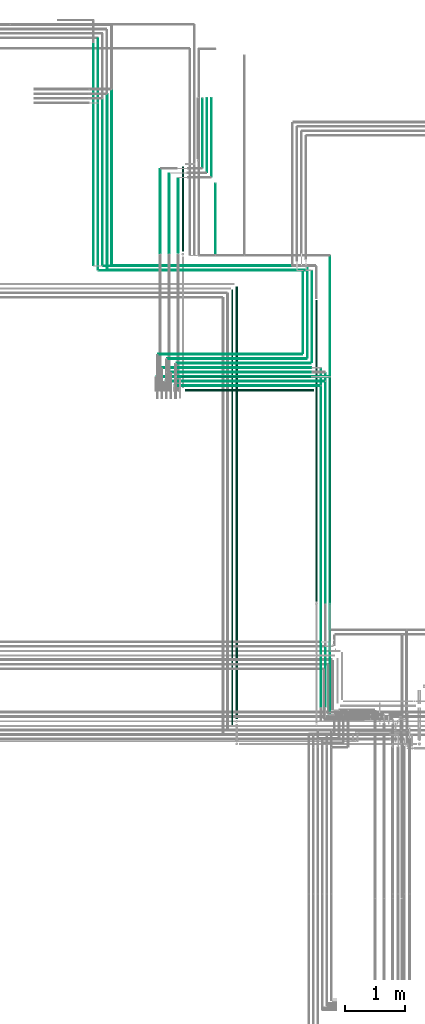
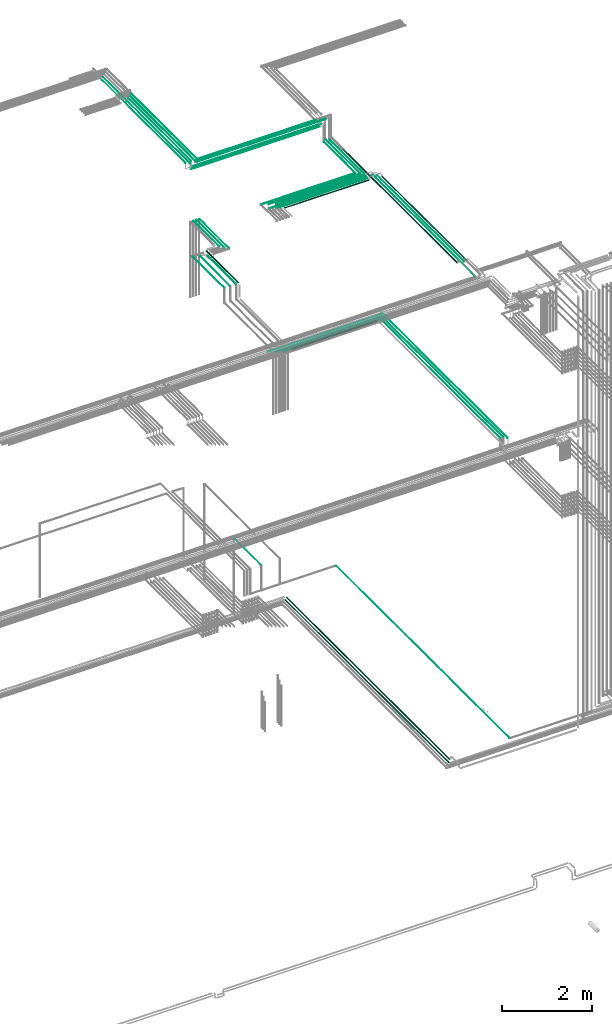
# One storey, part 110 of 331: 41 flow segments.
"""IFC2X3 building model written with IfcOpenShell, lengths in millimetres."""

from ifc_helpers import new_model, entity, si_unit, converted_unit, derived_unit, direction, frame, frame_2d, origin, origin_2d_with_axis, place, context, subcontext, project, spatial, circle, extrude, type_object, element, save


model = new_model("IFC2X3")

# Units and contexts
model_context = context("Model", 3, precision=0.01, world=origin(), true_north=direction((6.12303176911189e-17, 1.0)))
body_context = subcontext(model_context, "Body", "Model", "MODEL_VIEW")
ifc_project = project(units=[si_unit("LENGTHUNIT", "METRE", prefix="MILLI"), si_unit("AREAUNIT", "SQUARE_METRE"), si_unit("VOLUMEUNIT", "CUBIC_METRE"), converted_unit("PLANEANGLEUNIT", "DEGREE", entity("IfcRatioMeasure", 0.0174532925199433), si_unit("PLANEANGLEUNIT", "RADIAN"), dimensions=[0, 0, 0, 0, 0, 0, 0]), si_unit("MASSUNIT", "GRAM", prefix="KILO"), derived_unit("MASSDENSITYUNIT", [(si_unit("MASSUNIT", "GRAM", prefix="KILO"), 1), (si_unit("LENGTHUNIT", "METRE"), -3)]), derived_unit("MOMENTOFINERTIAUNIT", [(si_unit("LENGTHUNIT", "METRE"), 4)]), si_unit("TIMEUNIT", "SECOND"), si_unit("FREQUENCYUNIT", "HERTZ"), si_unit("THERMODYNAMICTEMPERATUREUNIT", "DEGREE_CELSIUS"), derived_unit("THERMALTRANSMITTANCEUNIT", [(si_unit("MASSUNIT", "GRAM", prefix="KILO"), 1), (si_unit("THERMODYNAMICTEMPERATUREUNIT", "KELVIN"), -1), (si_unit("TIMEUNIT", "SECOND"), -3)]), derived_unit("VOLUMETRICFLOWRATEUNIT", [(si_unit("LENGTHUNIT", "METRE"), 3), (si_unit("TIMEUNIT", "SECOND"), -1)]), derived_unit("MASSFLOWRATEUNIT", [(si_unit("MASSUNIT", "GRAM", prefix="KILO"), 1), (si_unit("TIMEUNIT", "SECOND"), -1)]), derived_unit("ROTATIONALFREQUENCYUNIT", [(si_unit("TIMEUNIT", "SECOND"), -1)]), si_unit("ELECTRICCURRENTUNIT", "AMPERE"), si_unit("ELECTRICVOLTAGEUNIT", "VOLT"), si_unit("POWERUNIT", "WATT"), si_unit("FORCEUNIT", "NEWTON", prefix="KILO"), si_unit("ILLUMINANCEUNIT", "LUX"), si_unit("LUMINOUSFLUXUNIT", "LUMEN"), si_unit("LUMINOUSINTENSITYUNIT", "CANDELA"), derived_unit("USERDEFINED", [(si_unit("MASSUNIT", "GRAM", prefix="KILO"), -1), (si_unit("LENGTHUNIT", "METRE"), -2), (si_unit("TIMEUNIT", "SECOND"), 3), (si_unit("LUMINOUSFLUXUNIT", "LUMEN"), 1)]), derived_unit("LINEARVELOCITYUNIT", [(si_unit("LENGTHUNIT", "METRE"), 1), (si_unit("TIMEUNIT", "SECOND"), -1)]), si_unit("PRESSUREUNIT", "PASCAL"), derived_unit("USERDEFINED", [(si_unit("LENGTHUNIT", "METRE"), -2), (si_unit("MASSUNIT", "GRAM", prefix="KILO"), 1), (si_unit("TIMEUNIT", "SECOND"), -2)]), derived_unit("LINEARFORCEUNIT", [(si_unit("MASSUNIT", "GRAM", prefix="KILO"), 1), (si_unit("LENGTHUNIT", "METRE"), 1), (si_unit("TIMEUNIT", "SECOND"), -2), (si_unit("LENGTHUNIT", "METRE"), -1)]), derived_unit("PLANARFORCEUNIT", [(si_unit("MASSUNIT", "GRAM", prefix="KILO"), 1), (si_unit("LENGTHUNIT", "METRE"), 1), (si_unit("TIMEUNIT", "SECOND"), -2), (si_unit("LENGTHUNIT", "METRE"), -2)])], contexts=[model_context])

# Site, building, storey
site_placement = place(None, frame((0.0, -0.00077364408347762, 0.0)))
site = spatial("IfcSite", under=ifc_project, at=site_placement, CompositionType="ELEMENT")
building_placement = place(site_placement, origin())
building = spatial("IfcBuilding", under=site, at=building_placement, CompositionType="ELEMENT")
storey_placement = place(building_placement, origin())
storey = spatial("IfcBuildingStorey", under=building, at=storey_placement, CompositionType="ELEMENT", Elevation=0.0)

# Flow segments
pipe_segment_type = type_object("IfcPipeSegmentType", PredefinedType="NOTDEFINED")
flow_segment_1_placement = place(storey_placement, frame((62212.5132590569, 8689.62056382736, 14742.4047277641)))
element("IfcFlowSegment", 1, at=flow_segment_1_placement, inside=storey, type_object=pipe_segment_type, context=body_context, shape_type="SweptSolid", body=[
    extrude(circle(Radius=6.0, at=origin_2d_with_axis()), frame((7.59527223591454, 0.0, 7.5952722359167), z_axis=(0.0, 1.0, 0.0), x_axis=(1.0, 0.0, 0.0)), (0.0, 0.0, 1.0), 5571.37943617266),
])
flow_segment_2_placement = place(storey_placement, frame((59329.8482219476, 14267.4047277641, 14692.4047277641)))
element("IfcFlowSegment", 2, at=flow_segment_2_placement, inside=storey, type_object=pipe_segment_type, context=body_context, shape_type="SweptSolid", body=[
    extrude(circle(Radius=6.0, at=origin_2d_with_axis()), frame((0.0, 7.5952722359297, 7.5952722359167), z_axis=(1.0, 0.0, 0.0), x_axis=(0.0, -1.0, 0.0)), (0.0, 0.0, 1.0), 2876.26030934531),
])
flow_segment_3_placement = place(storey_placement, frame((60239.5132627125, 17610.0, 15144.4047277641)))
element("IfcFlowSegment", 3, at=flow_segment_3_placement, inside=storey, type_object=pipe_segment_type, context=body_context, shape_type="SweptSolid", body=[
    extrude(circle(Radius=4.0, at=origin_2d_with_axis()), frame((5.59527223591499, 0.0, 5.59527223591499), z_axis=(0.0, 1.0, 0.0), x_axis=(1.0, 0.0, 0.0)), (0.0, 0.0, 1.0), 1311.62054191252),
])
flow_segment_4_placement = place(storey_placement, frame((62137.5132590569, 8764.62056382736, 14742.4047277641)))
element("IfcFlowSegment", 4, at=flow_segment_4_placement, inside=storey, type_object=pipe_segment_type, context=body_context, shape_type="SweptSolid", body=[
    extrude(circle(Radius=6.0, at=origin_2d_with_axis()), frame((7.59527223591454, 0.0, 7.5952722359167), z_axis=(0.0, 1.0, 0.0), x_axis=(1.0, 0.0, 0.0)), (0.0, 0.0, 1.0), 5421.37943617267),
])
flow_segment_5_placement = place(storey_placement, frame((62062.5132590569, 8764.62056382736, 14742.4047277641)))
element("IfcFlowSegment", 5, at=flow_segment_5_placement, inside=storey, type_object=pipe_segment_type, context=body_context, shape_type="SweptSolid", body=[
    extrude(circle(Radius=6.0, at=frame_2d((0.0, 2.16573425859679e-12), x_axis=(1.0, 0.0))), frame((7.59527223591454, 0.0, 7.59527223591887), z_axis=(0.0, 1.0, 0.0), x_axis=(1.0, 0.0, 0.0)), (0.0, 0.0, 1.0), 5346.37943617266),
])
flow_segment_6_placement = place(storey_placement, frame((59805.8482219476, 14030.9047277641, 14730.9047277641)))
element("IfcFlowSegment", 6, at=flow_segment_6_placement, inside=storey, type_object=pipe_segment_type, context=body_context, shape_type="SweptSolid", body=[
    extrude(circle(Radius=17.5, at=origin_2d_with_axis()), frame((0.0, 19.0952722359163, 19.0952722359163), z_axis=(1.0, 0.0, 0.0), x_axis=(0.0, -1.0, 0.0)), (0.0, 0.0, 1.0), 2149.26030934528),
])
flow_segment_7_placement = place(storey_placement, frame((59629.8482219476, 14117.4047277641, 14692.4047277641)))
element("IfcFlowSegment", 7, at=flow_segment_7_placement, inside=storey, type_object=pipe_segment_type, context=body_context, shape_type="SweptSolid", body=[
    extrude(circle(Radius=6.0, at=frame_2d((0.0, -2.16573425859679e-12), x_axis=(1.0, 0.0))), frame((0.0, 7.59527223592536, 7.59527223591454), z_axis=(1.0, 0.0, 0.0), x_axis=(0.0, -1.0, 0.0)), (0.0, 0.0, 1.0), 2426.26030934532),
])
flow_segment_8_placement = place(storey_placement, frame((59479.8482219475, 14192.4047277641, 14692.4047277641)))
element("IfcFlowSegment", 8, at=flow_segment_8_placement, inside=storey, type_object=pipe_segment_type, context=body_context, shape_type="SweptSolid", body=[
    extrude(circle(Radius=6.0, at=frame_2d((0.0, -2.16573425859679e-12), x_axis=(1.0, 0.0))), frame((0.0, 7.59527223592536, 7.59527223591454), z_axis=(1.0, 0.0, 0.0), x_axis=(0.0, -1.0, 0.0)), (0.0, 0.0, 1.0), 2651.26030934533),
])
flow_segment_9_placement = place(storey_placement, frame((60164.5132627125, 17685.0, 15144.4047277641)))
element("IfcFlowSegment", 9, at=flow_segment_9_placement, inside=storey, type_object=pipe_segment_type, context=body_context, shape_type="SweptSolid", body=[
    extrude(circle(Radius=4.0, at=origin_2d_with_axis()), frame((5.59527223591499, 0.0, 5.59527223591499), z_axis=(0.0, 1.0, 0.0), x_axis=(1.0, 0.0, 0.0)), (0.0, 0.0, 1.0), 1236.62054191252),
])
flow_segment_10_placement = place(storey_placement, frame((60087.5132627125, 17764.0, 15142.4047277641)))
element("IfcFlowSegment", 10, at=flow_segment_10_placement, inside=storey, type_object=pipe_segment_type, context=body_context, shape_type="SweptSolid", body=[
    extrude(circle(Radius=6.0, at=frame_2d((8.66293703438714e-12, 0.0), x_axis=(1.0, 0.0))), frame((7.59527223591454, 0.0, 7.5952722359167), z_axis=(0.0, 1.0, 0.0), x_axis=(-1.0, 0.0, 0.0)), (0.0, 0.0, 1.0), 1153.62054191252),
])
flow_segment_11_placement = place(storey_placement, frame((59383.2529497117, 16337.0683513783, 15142.4047277641)))
element("IfcFlowSegment", 11, at=flow_segment_11_placement, inside=storey, type_object=pipe_segment_type, context=body_context, shape_type="SweptSolid", body=[
    extrude(circle(Radius=6.0, at=origin_2d_with_axis()), frame((7.5952722359232, 0.0, 7.5952722359167), z_axis=(0.0, 1.0, 0.0), x_axis=(1.0, 0.0, 0.0)), (0.0, 0.0, 1.0), 1398.93167053658),
])
flow_segment_12_placement = place(storey_placement, frame((59533.2529497117, 16337.0683513783, 15142.4047277641)))
element("IfcFlowSegment", 12, at=flow_segment_12_placement, inside=storey, type_object=pipe_segment_type, context=body_context, shape_type="SweptSolid", body=[
    extrude(circle(Radius=6.0, at=origin_2d_with_axis()), frame((7.5952722359232, 0.0, 7.5952722359167), z_axis=(0.0, 1.0, 0.0), x_axis=(1.0, 0.0, 0.0)), (0.0, 0.0, 1.0), 1323.93167053657),
])
flow_segment_13_placement = place(storey_placement, frame((59681.7529497117, 16341.0683513783, 15140.9047277641)))
element("IfcFlowSegment", 13, at=flow_segment_13_placement, inside=storey, type_object=pipe_segment_type, context=body_context, shape_type="SweptSolid", body=[
    extrude(circle(Radius=7.5, at=frame_2d((0.0, -2.16573425859679e-12), x_axis=(1.0, 0.0))), frame((9.09527223591419, 0.0, 9.09527223591419), z_axis=(0.0, 1.0, 0.0), x_axis=(1.0, 0.0, 0.0)), (0.0, 0.0, 1.0), 1240.93167053658),
])
flow_segment_14_placement = place(storey_placement, frame((59746.7529497117, 16363.0683513783, 15130.9047277641)))
element("IfcFlowSegment", 14, at=flow_segment_14_placement, inside=storey, type_object=pipe_segment_type, context=body_context, shape_type="SweptSolid", body=[
    extrude(circle(Radius=17.5, at=frame_2d((-8.66293703438714e-12, 0.0), x_axis=(1.0, 0.0))), frame((19.0952722359379, 0.0, 19.0952722359163), z_axis=(0.0, 1.0, 0.0), x_axis=(1.0, 0.0, 0.0)), (0.0, 0.0, 1.0), 1421.93167053659),
])
flow_segment_15_placement = place(building_placement, frame((60309.3854351487, 16308.5068408728, 7344.40472776409)))
element("IfcFlowSegment", 15, at=flow_segment_15_placement, inside=storey, type_object=pipe_segment_type, context=body_context, shape_type="SweptSolid", body=[
    extrude(circle(Radius=4.0, at=origin_2d_with_axis()), frame((5.59527223591499, 0.0, 5.59527223591607), z_axis=(0.0, 1.0, 0.0), x_axis=(1.0, 0.0, 0.0)), (0.0, 0.0, 1.0), 1186.86112669117),
])
flow_segment_16_placement = place(storey_placement, frame((61977.0947663298, 10524.8107344822, 18430.9047277641)))
element("IfcFlowSegment", 16, at=flow_segment_16_placement, inside=storey, type_object=pipe_segment_type, context=body_context, shape_type="SweptSolid", body=[
    extrude(circle(Radius=17.5, at=origin_2d_with_axis()), frame((19.0952722359119, 0.0, 19.0952722359163), z_axis=(0.0, 1.0, 0.0), x_axis=(1.0, 0.0, 0.0)), (0.0, 0.0, 1.0), 5035.76431292158),
])
flow_segment_17_placement = place(storey_placement, frame((62063.5947663297, 9864.0, 18442.4047277641)))
element("IfcFlowSegment", 17, at=flow_segment_17_placement, inside=storey, type_object=pipe_segment_type, context=body_context, shape_type="SweptSolid", body=[
    extrude(circle(Radius=6.0, at=origin_2d_with_axis()), frame((7.59527223597518, 0.0, 7.5952722359167), z_axis=(0.0, 1.0, 0.0), x_axis=(1.0, 0.0, 0.0)), (0.0, 0.0, 1.0), 4547.00000000013),
])
flow_segment_18_placement = place(storey_placement, frame((62138.5947663298, 10498.8107344822, 18442.4047277641)))
element("IfcFlowSegment", 18, at=flow_segment_18_placement, inside=storey, type_object=pipe_segment_type, context=body_context, shape_type="SweptSolid", body=[
    extrude(circle(Radius=6.0, at=origin_2d_with_axis()), frame((7.59527223591454, 0.0, 7.5952722359167), z_axis=(0.0, 1.0, 0.0), x_axis=(1.0, 0.0, 0.0)), (0.0, 0.0, 1.0), 3837.18926551787),
])
flow_segment_19_placement = place(storey_placement, frame((62208.5947663298, 10508.8107344822, 18437.4047277641)))
element("IfcFlowSegment", 19, at=flow_segment_19_placement, inside=storey, type_object=pipe_segment_type, context=body_context, shape_type="SweptSolid", body=[
    extrude(circle(Radius=11.0, at=origin_2d_with_axis()), frame((12.5952722359134, 0.0, 12.5952722359156), z_axis=(0.0, 1.0, 0.0), x_axis=(1.0, 0.0, 0.0)), (0.0, 0.0, 1.0), 3742.18926551787),
])
flow_segment_20_placement = place(storey_placement, frame((59743.9167535511, 14262.4047277641, 18437.4047277641)))
element("IfcFlowSegment", 20, at=flow_segment_20_placement, inside=storey, type_object=pipe_segment_type, context=body_context, shape_type="SweptSolid", body=[
    extrude(circle(Radius=11.0, at=origin_2d_with_axis()), frame((0.0, 12.5952722359177, 12.5952722359156), z_axis=(1.0, 0.0, 0.0), x_axis=(0.0, 1.0, 0.0)), (0.0, 0.0, 1.0), 2153.27328501464),
])
flow_segment_21_placement = place(storey_placement, frame((59583.9167535511, 14342.4047277641, 18442.4047277641)))
element("IfcFlowSegment", 21, at=flow_segment_21_placement, inside=storey, type_object=pipe_segment_type, context=body_context, shape_type="SweptSolid", body=[
    extrude(circle(Radius=6.0, at=frame_2d((-4.33146851719357e-12, 0.0), x_axis=(1.0, 0.0))), frame((0.0, 7.59527223592103, 7.5952722359167), z_axis=(1.0, 0.0, 0.0), x_axis=(0.0, 1.0, 0.0)), (0.0, 0.0, 1.0), 2323.27328501465),
])
flow_segment_22_placement = place(storey_placement, frame((59433.9167535511, 14417.4047277641, 18442.4047277641)))
element("IfcFlowSegment", 22, at=flow_segment_22_placement, inside=storey, type_object=pipe_segment_type, context=body_context, shape_type="SweptSolid", body=[
    extrude(circle(Radius=6.0, at=frame_2d((-4.33146851719357e-12, 0.0), x_axis=(1.0, 0.0))), frame((0.0, 7.5952722359232, 7.5952722359167), z_axis=(1.0, 0.0, 0.0), x_axis=(0.0, 1.0, 0.0)), (0.0, 0.0, 1.0), 2473.27328501465),
])
flow_segment_23_placement = place(storey_placement, frame((59662.9167535511, 14490.9047277641, 18440.9047277641)))
element("IfcFlowSegment", 23, at=flow_segment_23_placement, inside=storey, type_object=pipe_segment_type, context=body_context, shape_type="SweptSolid", body=[
    extrude(circle(Radius=7.5, at=origin_2d_with_axis()), frame((0.0, 9.09527223591853, 9.09527223591636), z_axis=(1.0, 0.0, 0.0), x_axis=(0.0, 1.0, 0.0)), (0.0, 0.0, 1.0), 2240.27328501467),
])
flow_segment_24_placement = place(building_placement, frame((58595.1900385656, 16116.0146947319, 19040.9047277641)))
element("IfcFlowSegment", 24, at=flow_segment_24_placement, inside=storey, type_object=pipe_segment_type, context=body_context, shape_type="SweptSolid", body=[
    extrude(circle(Radius=7.5, at=frame_2d((-2.16573425859679e-12, 0.0), x_axis=(1.0, 0.0))), frame((0.0, 9.09527223591853, 9.09527223591636), z_axis=(1.0, 0.0, 0.0), x_axis=(0.0, 1.0, 0.0)), (0.0, 0.0, 1.0), 2993.00000000008),
])
flow_segment_25_placement = place(building_placement, frame((61912.0947663298, 14518.0, 18440.9047277641)))
element("IfcFlowSegment", 25, at=flow_segment_25_placement, inside=storey, type_object=pipe_segment_type, context=body_context, shape_type="SweptSolid", body=[
    extrude(circle(Radius=7.5, at=frame_2d((0.0, 2.16573425859679e-12), x_axis=(1.0, 0.0))), frame((9.09527223593152, 0.0, 9.09527223591853), z_axis=(0.0, 1.0, 0.0), x_axis=(1.0, 0.0, 0.0)), (0.0, 0.0, 1.0), 1514.10996696779),
])
flow_segment_26_placement = place(building_placement, frame((58520.1900385656, 16041.0146947319, 19040.9047277641)))
element("IfcFlowSegment", 26, at=flow_segment_26_placement, inside=storey, type_object=pipe_segment_type, context=body_context, shape_type="SweptSolid", body=[
    extrude(circle(Radius=7.5, at=frame_2d((6.49720277579036e-12, 0.0), x_axis=(1.0, 0.0))), frame((0.0, 9.09527223592286, 9.09527223591636), z_axis=(1.0, 0.0, 0.0), x_axis=(0.0, 1.0, 0.0)), (0.0, 0.0, 1.0), 3293.00000000009),
])
flow_segment_27_placement = place(building_placement, frame((59508.9167535511, 14567.4047277641, 18442.4047277641)))
element("IfcFlowSegment", 27, at=flow_segment_27_placement, inside=storey, type_object=pipe_segment_type, context=body_context, shape_type="SweptSolid", body=[
    extrude(circle(Radius=6.0, at=frame_2d((-4.33146851719357e-12, 0.0), x_axis=(1.0, 0.0))), frame((0.0, 7.5952722359232, 7.5952722359167), z_axis=(1.0, 0.0, 0.0), x_axis=(0.0, 1.0, 0.0)), (0.0, 0.0, 1.0), 2323.27328501467),
])
flow_segment_28_placement = place(building_placement, frame((61838.5947663298, 14589.0, 18442.4047277641)))
element("IfcFlowSegment", 28, at=flow_segment_28_placement, inside=storey, type_object=pipe_segment_type, context=body_context, shape_type="SweptSolid", body=[
    extrude(circle(Radius=6.0, at=origin_2d_with_axis()), frame((7.5952722359232, 0.0, 7.5952722359167), z_axis=(0.0, 1.0, 0.0), x_axis=(1.0, 0.0, 0.0)), (0.0, 0.0, 1.0), 1522.1099669678),
])
flow_segment_29_placement = place(building_placement, frame((59358.916753551, 14642.4047277641, 18442.4047277641)))
element("IfcFlowSegment", 29, at=flow_segment_29_placement, inside=storey, type_object=pipe_segment_type, context=body_context, shape_type="SweptSolid", body=[
    extrude(circle(Radius=6.0, at=frame_2d((-1.08286712929839e-11, -2.16573425859679e-12), x_axis=(1.0, 0.0))), frame((0.0, 7.59527223592753, 7.59527223591887), z_axis=(1.0, 0.0, 0.0), x_axis=(0.0, 1.0, 0.0)), (0.0, 0.0, 1.0), 2398.27328501469),
])
flow_segment_30_placement = place(building_placement, frame((61763.5947663298, 14664.0, 18442.4047277641)))
element("IfcFlowSegment", 30, at=flow_segment_30_placement, inside=storey, type_object=pipe_segment_type, context=body_context, shape_type="SweptSolid", body=[
    extrude(circle(Radius=6.0, at=origin_2d_with_axis()), frame((7.5952722359232, 0.0, 7.5952722359167), z_axis=(0.0, 1.0, 0.0), x_axis=(1.0, 0.0, 0.0)), (0.0, 0.0, 1.0), 1372.10996696781),
])
flow_segment_31_placement = place(building_placement, frame((58434.1900385656, 16117.5146947319, 18892.4047277641)))
element("IfcFlowSegment", 31, at=flow_segment_31_placement, inside=storey, type_object=pipe_segment_type, context=body_context, shape_type="SweptSolid", body=[
    extrude(circle(Radius=6.0, at=frame_2d((-8.66293703438714e-12, 4.33146851719357e-12), x_axis=(1.0, 0.0))), frame((0.0, 7.5952722359232, 7.5952722359232), z_axis=(1.0, 0.0, 0.0), x_axis=(0.0, 1.0, 0.0)), (0.0, 0.0, 1.0), 3305.00000000011),
])
flow_segment_32_placement = place(building_placement, frame((58366.1900385656, 16042.5146947319, 18892.4047277641)))
element("IfcFlowSegment", 32, at=flow_segment_32_placement, inside=storey, type_object=pipe_segment_type, context=body_context, shape_type="SweptSolid", body=[
    extrude(circle(Radius=6.0, at=frame_2d((-6.49720277579036e-12, 6.49720277579036e-12), x_axis=(1.0, 0.0))), frame((0.0, 7.59527223592536, 7.59527223592103), z_axis=(1.0, 0.0, 0.0), x_axis=(0.0, 1.0, 0.0)), (0.0, 0.0, 1.0), 3298.00000000011),
])
flow_segment_33_placement = place(building_placement, frame((58346.5947663297, 18859.2565182209, 19044.4047277641)))
element("IfcFlowSegment", 33, at=flow_segment_33_placement, inside=storey, type_object=pipe_segment_type, context=body_context, shape_type="SweptSolid", body=[
    extrude(circle(Radius=4.0, at=frame_2d((-1.73258740687743e-11, 0.0), x_axis=(1.0, 0.0))), frame((5.59527223593232, 0.0, 5.59527223591499), z_axis=(0.0, 1.0, 0.0), x_axis=(-1.0, 0.0, 0.0)), (0.0, 0.0, 1.0), 1055.74270813521),
])
flow_segment_34_placement = place(building_placement, frame((58568.0947663297, 16143.1099669678, 19040.9047277641)))
element("IfcFlowSegment", 34, at=flow_segment_34_placement, inside=storey, type_object=pipe_segment_type, context=body_context, shape_type="SweptSolid", body=[
    extrude(circle(Radius=7.5, at=frame_2d((-8.66293703438714e-12, 0.0), x_axis=(1.0, 0.0))), frame((9.09527223592286, 0.0, 9.09527223591636), z_axis=(0.0, 1.0, 0.0), x_axis=(1.0, 0.0, 0.0)), (0.0, 0.0, 1.0), 2920.14655125303),
])
flow_segment_35_placement = place(building_placement, frame((58493.0947663297, 16068.1099669678, 19040.9047277641)))
element("IfcFlowSegment", 35, at=flow_segment_35_placement, inside=storey, type_object=pipe_segment_type, context=body_context, shape_type="SweptSolid", body=[
    extrude(circle(Radius=7.5, at=origin_2d_with_axis()), frame((9.09527223591419, 0.0, 9.09527223591636), z_axis=(0.0, 1.0, 0.0), x_axis=(1.0, 0.0, 0.0)), (0.0, 0.0, 1.0), 2920.14655125306),
])
flow_segment_36_placement = place(building_placement, frame((58419.5947663297, 16139.1099669678, 19042.4047277641)))
element("IfcFlowSegment", 36, at=flow_segment_36_placement, inside=storey, type_object=pipe_segment_type, context=body_context, shape_type="SweptSolid", body=[
    extrude(circle(Radius=6.0, at=origin_2d_with_axis()), frame((7.59527223591454, 0.0, 7.5952722359167), z_axis=(0.0, 1.0, 0.0), x_axis=(1.0, 0.0, 0.0)), (0.0, 0.0, 1.0), 2775.14655125303),
])
flow_segment_37_placement = place(storey_placement, frame((58271.5947663297, 16135.1099669678, 19044.4047277641)))
element("IfcFlowSegment", 37, at=flow_segment_37_placement, inside=storey, type_object=pipe_segment_type, context=body_context, shape_type="SweptSolid", body=[
    extrude(circle(Radius=4.0, at=origin_2d_with_axis()), frame((5.59527223591499, 0.0, 5.59527223591499), z_axis=(0.0, 1.0, 0.0), x_axis=(1.0, 0.0, 0.0)), (0.0, 0.0, 1.0), 3704.88925938824),
])
flow_segment_38_placement = place(building_placement, frame((58344.5947663297, 16064.1099669678, 19042.4047277641)))
element("IfcFlowSegment", 38, at=flow_segment_38_placement, inside=storey, type_object=pipe_segment_type, context=body_context, shape_type="SweptSolid", body=[
    extrude(circle(Radius=6.0, at=origin_2d_with_axis()), frame((7.59527223591454, 0.0, 7.5952722359167), z_axis=(0.0, 1.0, 0.0), x_axis=(1.0, 0.0, 0.0)), (0.0, 0.0, 1.0), 2775.14655125302),
])
flow_segment_39_placement = place(building_placement, frame((60645.9014929007, 8562.98770456776, 6655.90472776407)))
element("IfcFlowSegment", 39, at=flow_segment_39_placement, inside=storey, type_object=pipe_segment_type, context=body_context, shape_type="SweptSolid", body=[
    extrude(circle(Radius=17.5, at=frame_2d((-8.66293703438714e-12, 0.0), x_axis=(1.0, 0.0))), frame((19.0952722359119, 0.0, 19.0952722359163), z_axis=(0.0, 1.0, 0.0), x_axis=(-1.0, 0.0, 0.0)), (0.0, 0.0, 1.0), 7221.99696563518),
])
flow_segment_40_placement = place(building_placement, frame((60577.4014929007, 8471.98770456778, 6662.40472776406)))
element("IfcFlowSegment", 40, at=flow_segment_40_placement, inside=storey, type_object=pipe_segment_type, context=body_context, shape_type="SweptSolid", body=[
    extrude(circle(Radius=11.0, at=origin_2d_with_axis()), frame((12.5952722359134, 0.0, 12.5952722359156), z_axis=(0.0, 1.0, 0.0), x_axis=(1.0, 0.0, 0.0)), (0.0, 0.0, 1.0), 7253.99696563505),
])
flow_segment_41_placement = place(building_placement, frame((62219.4023107719, 8607.98770456778, 6669.40472776408)))
element("IfcFlowSegment", 41, at=flow_segment_41_placement, inside=storey, type_object=pipe_segment_type, context=body_context, shape_type="SweptSolid", body=[
    extrude(circle(Radius=4.0, at=frame_2d((0.0, 1.08286712929839e-12), x_axis=(1.0, 0.0))), frame((5.59527223591499, 0.0, 5.59527223591716), z_axis=(0.0, 1.0, 0.0), x_axis=(1.0, 0.0, 0.0)), (0.0, 0.0, 1.0), 7680.519136305),
])

save(model, "model.ifc")
